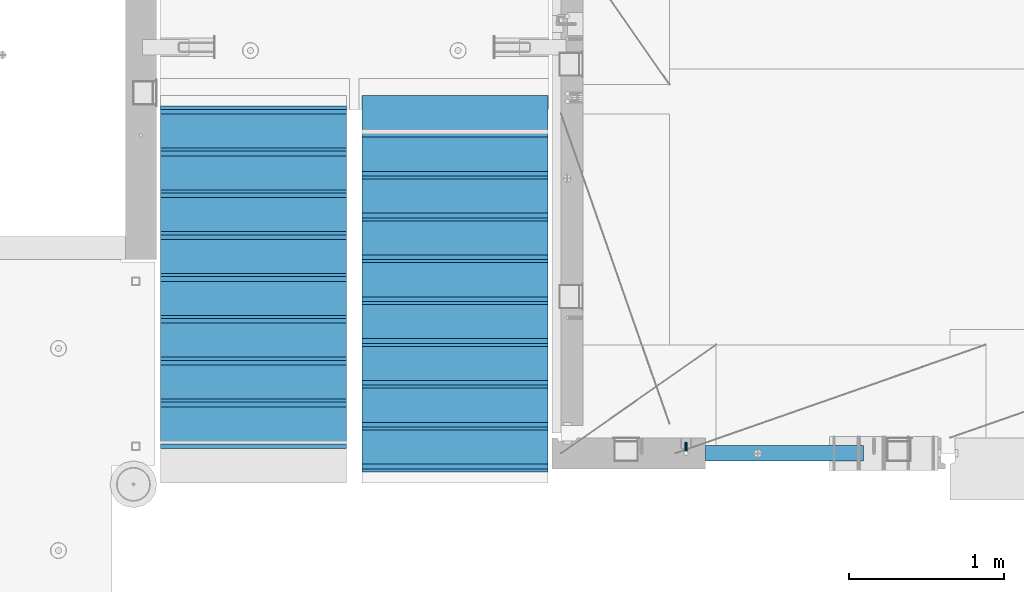
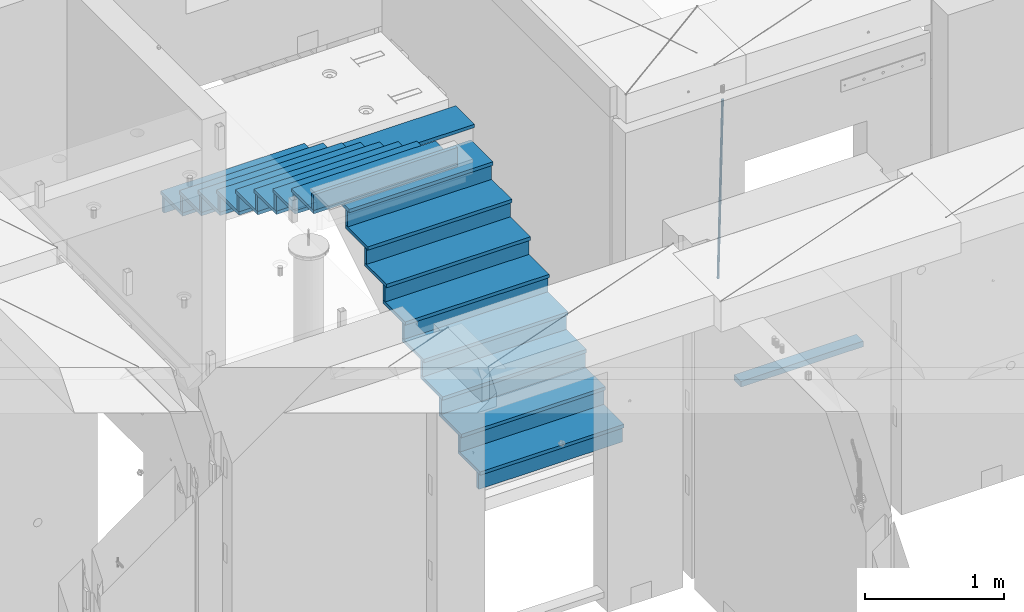
# One storey, part 114 of 341: 36 beams, 3 elements without a shape of their own.
"""IFC2X3 building model written with IfcOpenShell, lengths in millimetres."""

from ifc_helpers import new_model, si_unit, frame, origin_with_axes, place, context, subcontext, project, spatial, faceted_brep, material, type_object, element, aggregate, save


model = new_model("IFC2X3")

# Units and contexts
model_context = context("Model", 3, precision=1e-05, world=origin_with_axes())
body_context = subcontext(model_context, "Body", "Model", "MODEL_VIEW")
ifc_project = project(units=[si_unit("LENGTHUNIT", "METRE", prefix="MILLI"), si_unit("AREAUNIT", "SQUARE_METRE"), si_unit("VOLUMEUNIT", "CUBIC_METRE"), si_unit("MASSUNIT", "GRAM", prefix="KILO"), si_unit("TIMEUNIT", "SECOND"), si_unit("PLANEANGLEUNIT", "RADIAN"), si_unit("SOLIDANGLEUNIT", "STERADIAN"), si_unit("THERMODYNAMICTEMPERATUREUNIT", "DEGREE_CELSIUS"), si_unit("LUMINOUSINTENSITYUNIT", "LUMEN")], contexts=[model_context])

# Site, building, storey
site_placement = place(None, origin_with_axes())
site = spatial("IfcSite", under=ifc_project, at=site_placement, CompositionType="ELEMENT")
building_placement = place(site_placement, origin_with_axes())
building = spatial("IfcBuilding", under=site, at=building_placement, CompositionType="ELEMENT")
storey_placement = place(building_placement, origin_with_axes())
storey = spatial("IfcBuildingStorey", under=building, at=storey_placement, Name="5", CompositionType="ELEMENT", Elevation=0.0)

# Assembly, beams
assembly_1_placement = place(storey_placement, origin_with_axes())
assembly_1 = element("IfcElementAssembly", 1, at=assembly_1_placement, inside=storey, AssemblyPlace="NOTDEFINED", PredefinedType="REINFORCEMENT_UNIT")
ifc_material_1 = material()
beam_type_1 = type_object("IfcBeamType", Name="D20", PredefinedType="NOTDEFINED")
beam_1_placement = place(assembly_1_placement, frame((23075.0006866416, 17045.0000022791, 94790.0), z_axis=(0.00020576299992186, -0.999642804629538, -0.0267249099901004), x_axis=(-4.30000201928125e-08, -0.0267249099948059, 0.999642825806181)))
beam_1 = element("IfcBeam", 2, at=beam_1_placement, type_object=beam_type_1, material=ifc_material_1, Name="JM20", ObjectType="D20", context=body_context, shape_type="Brep", body=[
    faceted_brep([(0.0, -10.0, 0.0), (-4.19531716033816e-08, -7.07106781186667, -7.07106781187031), (60.4266690400545, -7.0710677960451, -7.07106780570757), (60.4266690441291, -9.99999998418934, 6.15546014159918e-09), (0.0, 0.0, -10.0), (60.426669036824, 1.58106558956206e-08, -9.99999999384454), (4.196772351861e-08, 7.07106781186303, -7.07106781186667), (60.4266690363438, 7.07106782768096, -7.07106780570757), (0.0, 10.0, 0.0), (60.4266690388904, 10.0000000158179, 6.15182216279209e-09), (4.196772351861e-08, 7.07106781185939, 7.07106781185939), (60.4266690429649, 7.07106782768096, 7.07106781802577), (0.0, 0.0, 10.0), (60.4266690461809, 1.58179318532348e-08, 10.0000000061555), (-4.19531716033816e-08, -7.07106781187031, 7.07106781185939), (60.4266690466611, -7.07106779605238, 7.07106781802213), (61.0378400410118, -7.07106779588503, -7.07106780564936), (60.991799419251, -9.99999998403655, 6.21366780251265e-09), (61.0569027789461, 1.5985278878361e-08, -9.99999999378269), (61.0378209396877, 7.07106782784831, -7.07106780564936), (60.9917724058905, 10.0000000159635, 6.21366780251265e-09), (60.9457317841297, 7.07106782781193, 7.0710678180767), (60.9266690461809, 1.59488990902901e-08, 10.0000000062028), (60.9457508854539, -7.07106779591413, 7.0710678180767), (61.6489592143771, -7.07106614513759, -7.06310863441468), (61.5568818710308, -9.9999984576425, 0.00735959856683621), (61.6870830769039, 1.71821739058942e-06, -9.99179257185824), (61.6489210170112, 7.07106947854481, -7.06310888312146), (61.556827851804, 10.0000015422847, 0.00735924683976918), (61.4647505084577, 7.07106922979438, 7.07782747982128), (61.4266266459163, 1.36643211590126e-06, 10.0065114172685), (61.464788705809, -7.07106639389531, 7.07782772852806), (176.543135720174, -7.07075579406956, -5.56673531796696), (176.451058376813, -9.99968810657447, 1.50373291501455), (176.581259582701, 0.000312069292704109, -8.49541925541052), (176.543097522794, 7.07137982961285, -5.56673556667374), (176.451004357587, 10.00031189336, 1.50373256329476), (176.35892701424, 7.07137958085514, 8.57420079627263), (176.320803151699, 0.000311717507429421, 11.5028847337162), (176.358965211621, -7.07075604281999, 8.57420104497578), (177.098753836006, -7.07075429323595, -5.55949898843028), (176.98362511232, -9.99968666800123, 1.510669025065), (177.146421932586, 0.000313595905026887, -8.48805862247536), (177.098706077581, 7.07138133041735, -5.55949936166144), (176.983557571715, 10.0003133318824, 1.51066849724157), (176.868428848029, 7.07138095712435, 8.58083651073321), (176.820760751449, 0.000313067976094317, 11.5093961447819), (176.868476606425, -7.07075466652896, 8.58083688396073), (177.654312950661, -7.07075204110879, -5.54863964998367), (177.516135294456, -9.99968450931192, 1.52107783331303), (177.711524267797, 0.000315886711177882, -8.47701274570863), (177.654255632195, 7.07138358250813, -5.54864021007961), (177.516054233929, 10.0003154905207, 1.5210770412159), (177.377876577739, 7.0713830223176, 8.59079452451624), (177.320665260588, 0.000315094497636892, 11.5191676202448), (177.377933896176, -7.07075260129932, 8.59079508461218), (299.580241614967, -7.07025777803938, -3.16539205229128), (299.442063958748, -9.99919024624614, 3.90432543100542), (299.637452932104, 0.000810149780591019, -6.09376514801625), (299.58018429653, 7.07187784557391, -3.16539261238358), (299.441982898265, 10.0008097535901, 3.90432463891557), (299.303805242045, 7.07187728538338, 10.974042122205), (299.246593924894, 0.00080935756341205, 13.9024152179336), (299.303862560482, -7.07025833822991, 10.9740426822973), (300.088882651282, -7.07025571611666, -3.15544980669438), (299.971788958996, -9.99918809853989, 3.91467979818117), (300.137357441272, 0.000812176291219657, -6.0839936725497), (300.088834180511, 7.07187990754028, -3.15545019384081), (299.971753863239, 10.0008119014747, 3.91467990454839), (299.854660170953, 7.07187951844026, 10.9848095094276), (299.806185380992, 0.000811626032373169, 13.9133533752902), (299.854708641738, -7.07025610520941, 10.9848098965813), (300.597573977022, -7.07025429077839, -3.14854421417112), (300.501599787152, -9.99918661431002, 3.92187219230618), (300.637311376035, 0.00081357714952901, -6.07720669196715), (300.597534354776, 7.07188133290401, -3.14854448120241), (300.501543752835, 10.0008133856099, 3.92187181466215), (300.40556956298, 7.07188106207104, 10.9922882211395), (300.365832163967, 0.000813194146758178, 13.9209506989318), (300.405609185211, -7.07025456160045, 10.9922884881707), (1494.60304651056, -7.06690872122999, 13.060333041718), (1494.50707232069, -9.99584104476162, 20.1307494481916), (1494.64278390956, 0.00415914670156781, 10.1316705639183), (1494.6030068883, 7.07522690244878, 13.0603327746867), (1494.50701628637, 10.004158955162, 20.1307490705476), (1494.4110420965, 7.07522663162308, 27.2011654770249), (1494.3713046975, 0.00415876370243495, 30.1298279548209), (1494.41108171875, -7.06690899205205, 27.2011657440526), (1495.1211563645, -7.06690726950183, 13.067366492749), (1495.00702625545, -9.99583964390331, 20.1375364287742), (1495.20660775043, 0.00416072652296862, 10.1393245920117), (1495.21332415029, 7.07522861253892, 13.0686179608165), (1495.13737118813, 10.0041607213934, 20.1393062718889), (1495.02324107911, 7.07522834699193, 27.2094762079141), (1494.93778969315, 0.00416035097441636, 30.1375181086514), (1494.93107329329, -7.06690753504881, 27.2082247398503), (1495.63922435709, -7.07365070849846, 13.0742491942874), (1495.5069397148, -10.00235861486, 20.1441724282631), (1495.77038591086, -0.00317370150150964, 10.1468279224828), (1495.82359171678, 7.06728286786529, 13.0767522910828), (1495.76767453534, 9.99594143344802, 20.1477123416917), (1495.63538989302, 7.0672335270865, 27.2176355756565), (1495.50422833927, -0.00324347991045215, 30.1450568474684), (1495.45102253335, -7.07370004928453, 27.2151324788683), (1517.48046966468, -7.35846502584536, 13.3649345949125), (1517.34818502239, -10.2871729322142, 20.4348578288809), (1517.61163121845, -0.287988018848409, 10.4375133231042), (1517.66483702436, 6.78246855052203, 13.3674376917079), (1517.60891984291, 9.71112711610476, 20.4383977423167), (1517.47663520063, 6.78241920973232, 27.5083209762815), (1517.34547364687, -0.288057797257352, 30.4357422480862), (1517.29226784095, -7.35851436663143, 27.5058178794898), (1518.11590717161, -7.36675126123009, 13.3733916404526), (1518.00827439407, -10.295780632965, 20.4436429663911), (1518.18994308249, -0.295529324139352, 10.4452100827657), (1518.18701289421, 6.77565927010801, 13.3743873367348), (1518.10883307132, 9.70460814510079, 20.4450510935785), (1518.00120029377, 6.77557877335857, 27.515302419517), (1517.9271643829, -0.295643163732166, 30.4434839772002), (1517.93009457119, -7.36683175797953, 27.5143067232275), (1518.75139849893, -7.36487536471395, 13.3816537936873), (1518.66841952164, -10.2938120781764, 20.4522328350286), (1518.76830418318, -0.293831718903675, 10.452712053142), (1518.7092334538, 6.77719739167878, 13.3811419616068), (1518.60878914295, 9.7060990139762, 20.4515089951637), (1518.52581016565, 6.77716230052101, 27.522088036505), (1518.50890448141, -0.293881345296541, 30.4510297770539), (1518.56797521077, -7.36491045587172, 27.5225998685855), (1618.77218426704, -7.06661321754655, 14.6790318180938), (1618.68920528975, -9.99554993101265, 21.7496108594387), (1618.78908995127, 0.0044304282637313, 11.7500900775485), (1618.73001922191, 7.07545953884255, 14.6785199860096), (1618.62957491104, 10.0043611611436, 21.748887019563), (1618.54659593375, 7.07542444768478, 28.8194660609042), (1618.52969024952, 0.00438080187086598, 31.7484078014531), (1618.58876097888, -7.06664830870795, 28.819977892992)], [[[0, 1, 2, 3]], [[1, 4, 5, 2]], [[4, 6, 7, 5]], [[6, 8, 9, 7]], [[8, 10, 11, 9]], [[10, 12, 13, 11]], [[12, 14, 15, 13]], [[14, 0, 3, 15]], [[14, 12, 10, 8, 6, 4, 1, 0]], [[3, 2, 16, 17]], [[2, 5, 18, 16]], [[5, 7, 19, 18]], [[7, 9, 20, 19]], [[9, 11, 21, 20]], [[11, 13, 22, 21]], [[13, 15, 23, 22]], [[15, 3, 17, 23]], [[17, 16, 24, 25]], [[16, 18, 26, 24]], [[18, 19, 27, 26]], [[19, 20, 28, 27]], [[20, 21, 29, 28]], [[21, 22, 30, 29]], [[22, 23, 31, 30]], [[23, 17, 25, 31]], [[25, 24, 32, 33]], [[24, 26, 34, 32]], [[26, 27, 35, 34]], [[27, 28, 36, 35]], [[28, 29, 37, 36]], [[29, 30, 38, 37]], [[30, 31, 39, 38]], [[31, 25, 33, 39]], [[33, 32, 40, 41]], [[32, 34, 42, 40]], [[34, 35, 43, 42]], [[35, 36, 44, 43]], [[36, 37, 45, 44]], [[37, 38, 46, 45]], [[38, 39, 47, 46]], [[39, 33, 41, 47]], [[41, 40, 48, 49]], [[40, 42, 50, 48]], [[42, 43, 51, 50]], [[43, 44, 52, 51]], [[44, 45, 53, 52]], [[45, 46, 54, 53]], [[46, 47, 55, 54]], [[47, 41, 49, 55]], [[49, 48, 56, 57]], [[48, 50, 58, 56]], [[50, 51, 59, 58]], [[51, 52, 60, 59]], [[52, 53, 61, 60]], [[53, 54, 62, 61]], [[54, 55, 63, 62]], [[55, 49, 57, 63]], [[57, 56, 64, 65]], [[56, 58, 66, 64]], [[58, 59, 67, 66]], [[59, 60, 68, 67]], [[60, 61, 69, 68]], [[61, 62, 70, 69]], [[62, 63, 71, 70]], [[63, 57, 65, 71]], [[65, 64, 72, 73]], [[64, 66, 74, 72]], [[66, 67, 75, 74]], [[67, 68, 76, 75]], [[68, 69, 77, 76]], [[69, 70, 78, 77]], [[70, 71, 79, 78]], [[71, 65, 73, 79]], [[73, 72, 80, 81]], [[72, 74, 82, 80]], [[74, 75, 83, 82]], [[75, 76, 84, 83]], [[76, 77, 85, 84]], [[77, 78, 86, 85]], [[78, 79, 87, 86]], [[79, 73, 81, 87]], [[81, 80, 88, 89]], [[80, 82, 90, 88]], [[82, 83, 91, 90]], [[83, 84, 92, 91]], [[84, 85, 93, 92]], [[85, 86, 94, 93]], [[86, 87, 95, 94]], [[87, 81, 89, 95]], [[89, 88, 96, 97]], [[88, 90, 98, 96]], [[90, 91, 99, 98]], [[91, 92, 100, 99]], [[92, 93, 101, 100]], [[93, 94, 102, 101]], [[94, 95, 103, 102]], [[95, 89, 97, 103]], [[97, 96, 104, 105]], [[96, 98, 106, 104]], [[98, 99, 107, 106]], [[99, 100, 108, 107]], [[100, 101, 109, 108]], [[101, 102, 110, 109]], [[102, 103, 111, 110]], [[103, 97, 105, 111]], [[105, 104, 112, 113]], [[104, 106, 114, 112]], [[106, 107, 115, 114]], [[107, 108, 116, 115]], [[108, 109, 117, 116]], [[109, 110, 118, 117]], [[110, 111, 119, 118]], [[111, 105, 113, 119]], [[113, 112, 120, 121]], [[112, 114, 122, 120]], [[114, 115, 123, 122]], [[115, 116, 124, 123]], [[116, 117, 125, 124]], [[117, 118, 126, 125]], [[118, 119, 127, 126]], [[119, 113, 121, 127]], [[121, 120, 128, 129]], [[120, 122, 130, 128]], [[122, 123, 131, 130]], [[123, 124, 132, 131]], [[124, 125, 133, 132]], [[125, 126, 134, 133]], [[126, 127, 135, 134]], [[127, 121, 129, 135]], [[130, 131, 132, 133, 134, 135, 129, 128]]]),
])
ifc_material_2 = material(Name="TIMBER/T24")
beam_type_2 = type_object("IfcBeamType", PredefinedType="NOTDEFINED")
beam_2_placement = place(assembly_1_placement, frame((23200.0006866455, 16980.0, 93880.0), z_axis=(0.0, 0.0, 1.0), x_axis=(1.0, 0.0, 0.0)))
beam_2 = element("IfcBeam", 3, at=beam_2_placement, type_object=beam_type_2, material=ifc_material_2, context=body_context, shape_type="Brep", body=[
    faceted_brep([(0.0, 50.0, -25.0), (0.0, 50.0, 25.0), (1020.0, 50.0, 25.0), (1020.0, 50.0, -25.0), (0.0, -50.0, 25.0), (1020.0, -50.0, 25.0), (0.0, -50.0, -25.0), (1020.0, -50.0, -25.0)], [[[0, 1, 2, 3]], [[1, 4, 5, 2]], [[4, 6, 7, 5]], [[6, 0, 3, 7]], [[5, 7, 3, 2]], [[6, 4, 1, 0]]]),
])
aggregate(assembly_1, [beam_1, beam_2])

assembly_2_placement = place(storey_placement, origin_with_axes())
assembly_2 = element("IfcElementAssembly", 4, at=assembly_2_placement, inside=storey, Name="E9", AssemblyPlace="NOTDEFINED", PredefinedType="NOTDEFINED")
ifc_material_3 = material(Name="Undefined/C32/40")
beam_type_3 = type_object("IfcBeamType", PredefinedType="NOTDEFINED")
beam_3_placement = place(assembly_2_placement, frame((20885.0002457424, 17024.9998138874, 96662.1), z_axis=(0.0, 1.0, 0.0), x_axis=(-1.0, 3.00000001838171e-08, 0.0)))
beam_3 = element("IfcBeam", 5, at=beam_3_placement, type_object=beam_type_3, material=ifc_material_3, Name="E9", context=body_context, shape_type="Brep", body=[
    faceted_brep([(0.0, 68.5, -15.0), (0.0, 68.5, 15.0), (1200.0, 68.5, 15.0), (1200.0, 68.5, -15.0), (0.0, -68.5, 15.0), (1200.0, -68.5, 15.0), (0.0, -68.5, -15.0), (1200.0, -68.5, -15.0)], [[[0, 1, 2, 3]], [[1, 4, 5, 2]], [[4, 6, 7, 5]], [[6, 0, 3, 7]], [[5, 7, 3, 2]], [[6, 4, 1, 0]]]),
])
beam_4_placement = place(assembly_2_placement, frame((20885.0002457424, 17294.9998138874, 96495.4), z_axis=(0.0, 1.0, 0.0), x_axis=(-1.0, 3.00000001838171e-08, 0.0)))
beam_4 = element("IfcBeam", 6, at=beam_4_placement, type_object=beam_type_3, material=ifc_material_3, Name="E9", context=body_context, shape_type="Brep", body=[
    faceted_brep([(0.0, 68.5, -15.0), (0.0, 68.5, 15.0), (1200.0, 68.5, 15.0), (1200.0, 68.5, -15.0), (0.0, -68.5, 15.0), (1200.0, -68.5, 15.0), (0.0, -68.5, -15.0), (1200.0, -68.5, -15.0)], [[[0, 1, 2, 3]], [[1, 4, 5, 2]], [[4, 6, 7, 5]], [[6, 0, 3, 7]], [[5, 7, 3, 2]], [[6, 4, 1, 0]]]),
])
beam_5_placement = place(assembly_2_placement, frame((20885.0002457424, 17564.9998138874, 96328.7), z_axis=(0.0, 1.0, 0.0), x_axis=(-1.0, 3.00000001838171e-08, 0.0)))
beam_5 = element("IfcBeam", 7, at=beam_5_placement, type_object=beam_type_3, material=ifc_material_3, Name="E9", context=body_context, shape_type="Brep", body=[
    faceted_brep([(0.0, 68.5, -15.0), (0.0, 68.5, 15.0), (1200.0, 68.5, 15.0), (1200.0, 68.5, -15.0), (0.0, -68.5, 15.0), (1200.0, -68.5, 15.0), (0.0, -68.5, -15.0), (1200.0, -68.5, -15.0)], [[[0, 1, 2, 3]], [[1, 4, 5, 2]], [[4, 6, 7, 5]], [[6, 0, 3, 7]], [[5, 7, 3, 2]], [[6, 4, 1, 0]]]),
])
beam_6_placement = place(assembly_2_placement, frame((20885.0002457424, 17834.9998138874, 96162.0), z_axis=(0.0, 1.0, 0.0), x_axis=(-1.0, 3.00000001838171e-08, 0.0)))
beam_6 = element("IfcBeam", 8, at=beam_6_placement, type_object=beam_type_3, material=ifc_material_3, Name="E9", context=body_context, shape_type="Brep", body=[
    faceted_brep([(0.0, 68.5, -15.0), (0.0, 68.5, 15.0), (1200.0, 68.5, 15.0), (1200.0, 68.5, -15.0), (0.0, -68.5, 15.0), (1200.0, -68.5, 15.0), (0.0, -68.5, -15.0), (1200.0, -68.5, -15.0)], [[[0, 1, 2, 3]], [[1, 4, 5, 2]], [[4, 6, 7, 5]], [[6, 0, 3, 7]], [[5, 7, 3, 2]], [[6, 4, 1, 0]]]),
])
beam_7_placement = place(assembly_2_placement, frame((20885.0002457424, 18104.9998138874, 95995.3), z_axis=(0.0, 1.0, 0.0), x_axis=(-1.0, 3.00000001838171e-08, 0.0)))
beam_7 = element("IfcBeam", 9, at=beam_7_placement, type_object=beam_type_3, material=ifc_material_3, Name="E9", context=body_context, shape_type="Brep", body=[
    faceted_brep([(0.0, 68.5, -15.0), (0.0, 68.5, 15.0), (1200.0, 68.5, 15.0), (1200.0, 68.5, -15.0), (0.0, -68.5, 15.0), (1200.0, -68.5, 15.0), (0.0, -68.5, -15.0), (1200.0, -68.5, -15.0)], [[[0, 1, 2, 3]], [[1, 4, 5, 2]], [[4, 6, 7, 5]], [[6, 0, 3, 7]], [[5, 7, 3, 2]], [[6, 4, 1, 0]]]),
])
beam_8_placement = place(assembly_2_placement, frame((20885.0002457424, 18374.9998138874, 95828.6), z_axis=(0.0, 1.0, 0.0), x_axis=(-1.0, 3.00000001838171e-08, 0.0)))
beam_8 = element("IfcBeam", 10, at=beam_8_placement, type_object=beam_type_3, material=ifc_material_3, Name="E9", context=body_context, shape_type="Brep", body=[
    faceted_brep([(0.0, 68.5, -15.0), (0.0, 68.5, 15.0), (1200.0, 68.5, 15.0), (1200.0, 68.5, -15.0), (0.0, -68.5, 15.0), (1200.0, -68.5, 15.0), (0.0, -68.5, -15.0), (1200.0, -68.5, -15.0)], [[[0, 1, 2, 3]], [[1, 4, 5, 2]], [[4, 6, 7, 5]], [[6, 0, 3, 7]], [[5, 7, 3, 2]], [[6, 4, 1, 0]]]),
])
beam_9_placement = place(assembly_2_placement, frame((20885.0002457424, 18644.9998138874, 95661.9), z_axis=(0.0, 1.0, 0.0), x_axis=(-1.0, 3.00000001838171e-08, 0.0)))
beam_9 = element("IfcBeam", 11, at=beam_9_placement, type_object=beam_type_3, material=ifc_material_3, Name="E9", context=body_context, shape_type="Brep", body=[
    faceted_brep([(0.0, 68.5, -15.0), (0.0, 68.5, 15.0), (1200.0, 68.5, 15.0), (1200.0, 68.5, -15.0), (0.0, -68.5, 15.0), (1200.0, -68.5, 15.0), (0.0, -68.5, -15.0), (1200.0, -68.5, -15.0)], [[[0, 1, 2, 3]], [[1, 4, 5, 2]], [[4, 6, 7, 5]], [[6, 0, 3, 7]], [[5, 7, 3, 2]], [[6, 4, 1, 0]]]),
])
beam_10_placement = place(assembly_2_placement, frame((20885.0002457424, 18914.9998138874, 95495.2), z_axis=(0.0, 1.0, 0.0), x_axis=(-1.0, 3.00000001838171e-08, 0.0)))
beam_10 = element("IfcBeam", 12, at=beam_10_placement, type_object=beam_type_3, material=ifc_material_3, Name="E9", context=body_context, shape_type="Brep", body=[
    faceted_brep([(0.0, 68.5, -15.0), (0.0, 68.5, 15.0), (1200.0, 68.5, 15.0), (1200.0, 68.5, -15.0), (0.0, -68.5, 15.0), (1200.0, -68.5, 15.0), (0.0, -68.5, -15.0), (1200.0, -68.5, -15.0)], [[[0, 1, 2, 3]], [[1, 4, 5, 2]], [[4, 6, 7, 5]], [[6, 0, 3, 7]], [[5, 7, 3, 2]], [[6, 4, 1, 0]]]),
])
beam_11_placement = place(assembly_2_placement, frame((20885.0002457424, 19184.9998138874, 95328.5), z_axis=(0.0, 1.0, 0.0), x_axis=(-1.0, 3.00000001838171e-08, 0.0)))
beam_11 = element("IfcBeam", 13, at=beam_11_placement, type_object=beam_type_3, material=ifc_material_3, Name="E9", context=body_context, shape_type="Brep", body=[
    faceted_brep([(0.0, 68.5, -15.0), (0.0, 68.5, 15.0), (1200.0, 68.5, 15.0), (1200.0, 68.5, -15.0), (0.0, -68.5, 15.0), (1200.0, -68.5, 15.0), (0.0, -68.5, -15.0), (1200.0, -68.5, -15.0)], [[[0, 1, 2, 3]], [[1, 4, 5, 2]], [[4, 6, 7, 5]], [[6, 0, 3, 7]], [[5, 7, 3, 2]], [[6, 4, 1, 0]]]),
])

assembly_3_placement = place(storey_placement, origin_with_axes())
assembly_3 = element("IfcElementAssembly", 14, at=assembly_3_placement, inside=storey, Name="E9", AssemblyPlace="NOTDEFINED", PredefinedType="NOTDEFINED")
beam_12_placement = place(assembly_3_placement, frame((20985.002175553, 18785.001025346, 94995.1036072969), z_axis=(0.0, -1.0, 0.0), x_axis=(1.0, 0.0, 0.0)))
beam_12 = element("IfcBeam", 15, at=beam_12_placement, type_object=beam_type_3, material=ifc_material_3, Name="E9", context=body_context, shape_type="Brep", body=[
    faceted_brep([(0.0, 68.5, -15.0), (0.0, 68.5, 15.0), (1200.0, 68.5, 15.0), (1200.0, 68.5, -15.0), (0.0, -68.5, 15.0), (1200.0, -68.5, 15.0), (0.0, -68.5, -15.0), (1200.0, -68.5, -15.0)], [[[0, 1, 2, 3]], [[1, 4, 5, 2]], [[4, 6, 7, 5]], [[6, 0, 3, 7]], [[5, 7, 3, 2]], [[6, 4, 1, 0]]]),
])
beam_13_placement = place(assembly_3_placement, frame((20985.002175553, 18515.001025346, 94828.4036072969), z_axis=(0.0, -1.0, 0.0), x_axis=(1.0, 0.0, 0.0)))
beam_13 = element("IfcBeam", 16, at=beam_13_placement, type_object=beam_type_3, material=ifc_material_3, Name="E9", context=body_context, shape_type="Brep", body=[
    faceted_brep([(0.0, 68.5, -15.0), (0.0, 68.5, 15.0), (1200.0, 68.5, 15.0), (1200.0, 68.5, -15.0), (0.0, -68.5, 15.0), (1200.0, -68.5, 15.0), (0.0, -68.5, -15.0), (1200.0, -68.5, -15.0)], [[[0, 1, 2, 3]], [[1, 4, 5, 2]], [[4, 6, 7, 5]], [[6, 0, 3, 7]], [[5, 7, 3, 2]], [[6, 4, 1, 0]]]),
])
beam_14_placement = place(assembly_3_placement, frame((20985.002175553, 18245.001025346, 94661.7036072969), z_axis=(0.0, -1.0, 0.0), x_axis=(1.0, 0.0, 0.0)))
beam_14 = element("IfcBeam", 17, at=beam_14_placement, type_object=beam_type_3, material=ifc_material_3, Name="E9", context=body_context, shape_type="Brep", body=[
    faceted_brep([(0.0, 68.5, -15.0), (0.0, 68.5, 15.0), (1200.0, 68.5, 15.0), (1200.0, 68.5, -15.0), (0.0, -68.5, 15.0), (1200.0, -68.5, 15.0), (0.0, -68.5, -15.0), (1200.0, -68.5, -15.0)], [[[0, 1, 2, 3]], [[1, 4, 5, 2]], [[4, 6, 7, 5]], [[6, 0, 3, 7]], [[5, 7, 3, 2]], [[6, 4, 1, 0]]]),
])
beam_15_placement = place(assembly_3_placement, frame((20985.002175553, 17975.001025346, 94495.0036072969), z_axis=(0.0, -1.0, 0.0), x_axis=(1.0, 0.0, 0.0)))
beam_15 = element("IfcBeam", 18, at=beam_15_placement, type_object=beam_type_3, material=ifc_material_3, Name="E9", context=body_context, shape_type="Brep", body=[
    faceted_brep([(0.0, 68.5, -15.0), (0.0, 68.5, 15.0), (1200.0, 68.5, 15.0), (1200.0, 68.5, -15.0), (0.0, -68.5, 15.0), (1200.0, -68.5, 15.0), (0.0, -68.5, -15.0), (1200.0, -68.5, -15.0)], [[[0, 1, 2, 3]], [[1, 4, 5, 2]], [[4, 6, 7, 5]], [[6, 0, 3, 7]], [[5, 7, 3, 2]], [[6, 4, 1, 0]]]),
])
beam_16_placement = place(assembly_3_placement, frame((20985.002175553, 17705.001025346, 94328.3036072969), z_axis=(0.0, -1.0, 0.0), x_axis=(1.0, 0.0, 0.0)))
beam_16 = element("IfcBeam", 19, at=beam_16_placement, type_object=beam_type_3, material=ifc_material_3, Name="E9", context=body_context, shape_type="Brep", body=[
    faceted_brep([(0.0, 68.5, -15.0), (0.0, 68.5, 15.0), (1200.0, 68.5, 15.0), (1200.0, 68.5, -15.0), (0.0, -68.5, 15.0), (1200.0, -68.5, 15.0), (0.0, -68.5, -15.0), (1200.0, -68.5, -15.0)], [[[0, 1, 2, 3]], [[1, 4, 5, 2]], [[4, 6, 7, 5]], [[6, 0, 3, 7]], [[5, 7, 3, 2]], [[6, 4, 1, 0]]]),
])
beam_17_placement = place(assembly_3_placement, frame((20985.002175553, 17435.001025346, 94161.6036072969), z_axis=(0.0, -1.0, 0.0), x_axis=(1.0, 0.0, 0.0)))
beam_17 = element("IfcBeam", 20, at=beam_17_placement, type_object=beam_type_3, material=ifc_material_3, Name="E9", context=body_context, shape_type="Brep", body=[
    faceted_brep([(0.0, 68.5, -15.0), (0.0, 68.5, 15.0), (1200.0, 68.5, 15.0), (1200.0, 68.5, -15.0), (0.0, -68.5, 15.0), (1200.0, -68.5, 15.0), (0.0, -68.5, -15.0), (1200.0, -68.5, -15.0)], [[[0, 1, 2, 3]], [[1, 4, 5, 2]], [[4, 6, 7, 5]], [[6, 0, 3, 7]], [[5, 7, 3, 2]], [[6, 4, 1, 0]]]),
])
beam_18_placement = place(assembly_3_placement, frame((20985.002175553, 17165.001025346, 93994.9036072969), z_axis=(0.0, -1.0, 0.0), x_axis=(1.0, 0.0, 0.0)))
beam_18 = element("IfcBeam", 21, at=beam_18_placement, type_object=beam_type_3, material=ifc_material_3, Name="E9", context=body_context, shape_type="Brep", body=[
    faceted_brep([(0.0, 68.5, -15.0), (0.0, 68.5, 15.0), (1200.0, 68.5, 15.0), (1200.0, 68.5, -15.0), (0.0, -68.5, 15.0), (1200.0, -68.5, 15.0), (0.0, -68.5, -15.0), (1200.0, -68.5, -15.0)], [[[0, 1, 2, 3]], [[1, 4, 5, 2]], [[4, 6, 7, 5]], [[6, 0, 3, 7]], [[5, 7, 3, 2]], [[6, 4, 1, 0]]]),
])
beam_19_placement = place(assembly_3_placement, frame((20985.002175553, 16895.001025346, 93828.2036072969), z_axis=(0.0, -1.0, 0.0), x_axis=(1.0, 0.0, 0.0)))
beam_19 = element("IfcBeam", 22, at=beam_19_placement, type_object=beam_type_3, material=ifc_material_3, Name="E9", context=body_context, shape_type="Brep", body=[
    faceted_brep([(0.0, 68.5, -15.0), (0.0, 68.5, 15.0), (1200.0, 68.5, 15.0), (1200.0, 68.5, -15.0), (0.0, -68.5, 15.0), (1200.0, -68.5, 15.0), (0.0, -68.5, -15.0), (1200.0, -68.5, -15.0)], [[[0, 1, 2, 3]], [[1, 4, 5, 2]], [[4, 6, 7, 5]], [[6, 0, 3, 7]], [[5, 7, 3, 2]], [[6, 4, 1, 0]]]),
])

# Beam
beam_type_4 = type_object("IfcBeamType", PredefinedType="NOTDEFINED")
beam_20_placement = place(assembly_2_placement, frame((20885.0002457424, 17169.9998138874, 96578.6), z_axis=(0.0, 1.0, 0.0), x_axis=(-1.0, 3.00000001838171e-08, 0.0)))
beam_20 = element("IfcBeam", 23, at=beam_20_placement, type_object=beam_type_4, material=ifc_material_3, Name="E9", context=body_context, shape_type="Brep", body=[
    faceted_brep([(0.0, 15.0, -160.0), (0.0, 15.0, 160.0), (1200.0, 15.0, 160.0), (1200.0, 15.0, -160.0), (0.0, -15.0, 160.0), (1200.0, -15.0, 160.0), (0.0, -15.0, -160.0), (1200.0, -15.0, -160.0)], [[[0, 1, 2, 3]], [[1, 4, 5, 2]], [[4, 6, 7, 5]], [[6, 0, 3, 7]], [[5, 7, 3, 2]], [[6, 4, 1, 0]]]),
])

beam_21_placement = place(assembly_2_placement, frame((20885.0002457424, 17439.9998138874, 96411.9), z_axis=(0.0, 1.0, 0.0), x_axis=(-1.0, 3.00000001838171e-08, 0.0)))
beam_21 = element("IfcBeam", 24, at=beam_21_placement, type_object=beam_type_4, material=ifc_material_3, Name="E9", context=body_context, shape_type="Brep", body=[
    faceted_brep([(0.0, 15.0, -160.0), (0.0, 15.0, 160.0), (1200.0, 15.0, 160.0), (1200.0, 15.0, -160.0), (0.0, -15.0, 160.0), (1200.0, -15.0, 160.0), (0.0, -15.0, -160.0), (1200.0, -15.0, -160.0)], [[[0, 1, 2, 3]], [[1, 4, 5, 2]], [[4, 6, 7, 5]], [[6, 0, 3, 7]], [[5, 7, 3, 2]], [[6, 4, 1, 0]]]),
])

beam_22_placement = place(assembly_2_placement, frame((20885.0002457424, 17709.9998138874, 96245.2), z_axis=(0.0, 1.0, 0.0), x_axis=(-1.0, 3.00000001838171e-08, 0.0)))
beam_22 = element("IfcBeam", 25, at=beam_22_placement, type_object=beam_type_4, material=ifc_material_3, Name="E9", context=body_context, shape_type="Brep", body=[
    faceted_brep([(0.0, 15.0, -160.0), (0.0, 15.0, 160.0), (1200.0, 15.0, 160.0), (1200.0, 15.0, -160.0), (0.0, -15.0, 160.0), (1200.0, -15.0, 160.0), (0.0, -15.0, -160.0), (1200.0, -15.0, -160.0)], [[[0, 1, 2, 3]], [[1, 4, 5, 2]], [[4, 6, 7, 5]], [[6, 0, 3, 7]], [[5, 7, 3, 2]], [[6, 4, 1, 0]]]),
])

beam_23_placement = place(assembly_2_placement, frame((20885.0002457424, 17979.9998138874, 96078.5), z_axis=(0.0, 1.0, 0.0), x_axis=(-1.0, 3.00000001838171e-08, 0.0)))
beam_23 = element("IfcBeam", 26, at=beam_23_placement, type_object=beam_type_4, material=ifc_material_3, Name="E9", context=body_context, shape_type="Brep", body=[
    faceted_brep([(0.0, 15.0, -160.0), (0.0, 15.0, 160.0), (1200.0, 15.0, 160.0), (1200.0, 15.0, -160.0), (0.0, -15.0, 160.0), (1200.0, -15.0, 160.0), (0.0, -15.0, -160.0), (1200.0, -15.0, -160.0)], [[[0, 1, 2, 3]], [[1, 4, 5, 2]], [[4, 6, 7, 5]], [[6, 0, 3, 7]], [[5, 7, 3, 2]], [[6, 4, 1, 0]]]),
])

beam_24_placement = place(assembly_2_placement, frame((20885.0002457424, 18249.9998138874, 95911.8), z_axis=(0.0, 1.0, 0.0), x_axis=(-1.0, 3.00000001838171e-08, 0.0)))
beam_24 = element("IfcBeam", 27, at=beam_24_placement, type_object=beam_type_4, material=ifc_material_3, Name="E9", context=body_context, shape_type="Brep", body=[
    faceted_brep([(0.0, 15.0, -160.0), (0.0, 15.0, 160.0), (1200.0, 15.0, 160.0), (1200.0, 15.0, -160.0), (0.0, -15.0, 160.0), (1200.0, -15.0, 160.0), (0.0, -15.0, -160.0), (1200.0, -15.0, -160.0)], [[[0, 1, 2, 3]], [[1, 4, 5, 2]], [[4, 6, 7, 5]], [[6, 0, 3, 7]], [[5, 7, 3, 2]], [[6, 4, 1, 0]]]),
])

beam_25_placement = place(assembly_2_placement, frame((20885.0002457424, 18519.9998138874, 95745.1), z_axis=(0.0, 1.0, 0.0), x_axis=(-1.0, 3.00000001838171e-08, 0.0)))
beam_25 = element("IfcBeam", 28, at=beam_25_placement, type_object=beam_type_4, material=ifc_material_3, Name="E9", context=body_context, shape_type="Brep", body=[
    faceted_brep([(0.0, 15.0, -160.0), (0.0, 15.0, 160.0), (1200.0, 15.0, 160.0), (1200.0, 15.0, -160.0), (0.0, -15.0, 160.0), (1200.0, -15.0, 160.0), (0.0, -15.0, -160.0), (1200.0, -15.0, -160.0)], [[[0, 1, 2, 3]], [[1, 4, 5, 2]], [[4, 6, 7, 5]], [[6, 0, 3, 7]], [[5, 7, 3, 2]], [[6, 4, 1, 0]]]),
])

beam_26_placement = place(assembly_2_placement, frame((20885.0002457424, 18789.9998138874, 95578.4), z_axis=(0.0, 1.0, 0.0), x_axis=(-1.0, 3.00000001838171e-08, 0.0)))
beam_26 = element("IfcBeam", 29, at=beam_26_placement, type_object=beam_type_4, material=ifc_material_3, Name="E9", context=body_context, shape_type="Brep", body=[
    faceted_brep([(0.0, 15.0, -160.0), (0.0, 15.0, 160.0), (1200.0, 15.0, 160.0), (1200.0, 15.0, -160.0), (0.0, -15.0, 160.0), (1200.0, -15.0, 160.0), (0.0, -15.0, -160.0), (1200.0, -15.0, -160.0)], [[[0, 1, 2, 3]], [[1, 4, 5, 2]], [[4, 6, 7, 5]], [[6, 0, 3, 7]], [[5, 7, 3, 2]], [[6, 4, 1, 0]]]),
])

beam_27_placement = place(assembly_2_placement, frame((20885.0002457424, 19059.9998138874, 95411.7), z_axis=(0.0, 1.0, 0.0), x_axis=(-1.0, 3.00000001838171e-08, 0.0)))
beam_27 = element("IfcBeam", 30, at=beam_27_placement, type_object=beam_type_4, material=ifc_material_3, Name="E9", context=body_context, shape_type="Brep", body=[
    faceted_brep([(0.0, 15.0, -160.0), (0.0, 15.0, 160.0), (1200.0, 15.0, 160.0), (1200.0, 15.0, -160.0), (0.0, -15.0, 160.0), (1200.0, -15.0, 160.0), (0.0, -15.0, -160.0), (1200.0, -15.0, -160.0)], [[[0, 1, 2, 3]], [[1, 4, 5, 2]], [[4, 6, 7, 5]], [[6, 0, 3, 7]], [[5, 7, 3, 2]], [[6, 4, 1, 0]]]),
])

aggregate(assembly_2, [beam_3, beam_20, beam_4, beam_21, beam_5, beam_22, beam_6, beam_23, beam_7, beam_24, beam_8, beam_25, beam_9, beam_26, beam_10, beam_27, beam_11])

beam_28_placement = place(assembly_3_placement, frame((20985.002175553, 18910.001025346, 95078.303607297), z_axis=(0.0, -1.0, 0.0), x_axis=(1.0, 0.0, 0.0)))
beam_28 = element("IfcBeam", 31, at=beam_28_placement, type_object=beam_type_4, material=ifc_material_3, Name="E9", context=body_context, shape_type="Brep", body=[
    faceted_brep([(0.0, 15.0, -160.0), (0.0, 15.0, 160.0), (1200.0, 15.0, 160.0), (1200.0, 15.0, -160.0), (0.0, -15.0, 160.0), (1200.0, -15.0, 160.0), (0.0, -15.0, -160.0), (1200.0, -15.0, -160.0)], [[[0, 1, 2, 3]], [[1, 4, 5, 2]], [[4, 6, 7, 5]], [[6, 0, 3, 7]], [[5, 7, 3, 2]], [[6, 4, 1, 0]]]),
])

beam_29_placement = place(assembly_3_placement, frame((20985.002175553, 18640.001025346, 94911.6036072969), z_axis=(0.0, -1.0, 0.0), x_axis=(1.0, 0.0, 0.0)))
beam_29 = element("IfcBeam", 32, at=beam_29_placement, type_object=beam_type_4, material=ifc_material_3, Name="E9", context=body_context, shape_type="Brep", body=[
    faceted_brep([(0.0, 15.0, -160.0), (0.0, 15.0, 160.0), (1200.0, 15.0, 160.0), (1200.0, 15.0, -160.0), (0.0, -15.0, 160.0), (1200.0, -15.0, 160.0), (0.0, -15.0, -160.0), (1200.0, -15.0, -160.0)], [[[0, 1, 2, 3]], [[1, 4, 5, 2]], [[4, 6, 7, 5]], [[6, 0, 3, 7]], [[5, 7, 3, 2]], [[6, 4, 1, 0]]]),
])

beam_30_placement = place(assembly_3_placement, frame((20985.002175553, 18370.001025346, 94744.9036072969), z_axis=(0.0, -1.0, 0.0), x_axis=(1.0, 0.0, 0.0)))
beam_30 = element("IfcBeam", 33, at=beam_30_placement, type_object=beam_type_4, material=ifc_material_3, Name="E9", context=body_context, shape_type="Brep", body=[
    faceted_brep([(0.0, 15.0, -160.0), (0.0, 15.0, 160.0), (1200.0, 15.0, 160.0), (1200.0, 15.0, -160.0), (0.0, -15.0, 160.0), (1200.0, -15.0, 160.0), (0.0, -15.0, -160.0), (1200.0, -15.0, -160.0)], [[[0, 1, 2, 3]], [[1, 4, 5, 2]], [[4, 6, 7, 5]], [[6, 0, 3, 7]], [[5, 7, 3, 2]], [[6, 4, 1, 0]]]),
])

beam_31_placement = place(assembly_3_placement, frame((20985.002175553, 18100.001025346, 94578.2036072969), z_axis=(0.0, -1.0, 0.0), x_axis=(1.0, 0.0, 0.0)))
beam_31 = element("IfcBeam", 34, at=beam_31_placement, type_object=beam_type_4, material=ifc_material_3, Name="E9", context=body_context, shape_type="Brep", body=[
    faceted_brep([(0.0, 15.0, -160.0), (0.0, 15.0, 160.0), (1200.0, 15.0, 160.0), (1200.0, 15.0, -160.0), (0.0, -15.0, 160.0), (1200.0, -15.0, 160.0), (0.0, -15.0, -160.0), (1200.0, -15.0, -160.0)], [[[0, 1, 2, 3]], [[1, 4, 5, 2]], [[4, 6, 7, 5]], [[6, 0, 3, 7]], [[5, 7, 3, 2]], [[6, 4, 1, 0]]]),
])

beam_32_placement = place(assembly_3_placement, frame((20985.002175553, 17830.001025346, 94411.5036072969), z_axis=(0.0, -1.0, 0.0), x_axis=(1.0, 0.0, 0.0)))
beam_32 = element("IfcBeam", 35, at=beam_32_placement, type_object=beam_type_4, material=ifc_material_3, Name="E9", context=body_context, shape_type="Brep", body=[
    faceted_brep([(0.0, 15.0, -160.0), (0.0, 15.0, 160.0), (1200.0, 15.0, 160.0), (1200.0, 15.0, -160.0), (0.0, -15.0, 160.0), (1200.0, -15.0, 160.0), (0.0, -15.0, -160.0), (1200.0, -15.0, -160.0)], [[[0, 1, 2, 3]], [[1, 4, 5, 2]], [[4, 6, 7, 5]], [[6, 0, 3, 7]], [[5, 7, 3, 2]], [[6, 4, 1, 0]]]),
])

beam_33_placement = place(assembly_3_placement, frame((20985.002175553, 17560.001025346, 94244.8036072969), z_axis=(0.0, -1.0, 0.0), x_axis=(1.0, 0.0, 0.0)))
beam_33 = element("IfcBeam", 36, at=beam_33_placement, type_object=beam_type_4, material=ifc_material_3, Name="E9", context=body_context, shape_type="Brep", body=[
    faceted_brep([(0.0, 15.0, -160.0), (0.0, 15.0, 160.0), (1200.0, 15.0, 160.0), (1200.0, 15.0, -160.0), (0.0, -15.0, 160.0), (1200.0, -15.0, 160.0), (0.0, -15.0, -160.0), (1200.0, -15.0, -160.0)], [[[0, 1, 2, 3]], [[1, 4, 5, 2]], [[4, 6, 7, 5]], [[6, 0, 3, 7]], [[5, 7, 3, 2]], [[6, 4, 1, 0]]]),
])

beam_34_placement = place(assembly_3_placement, frame((20985.002175553, 17290.001025346, 94078.1036072969), z_axis=(0.0, -1.0, 0.0), x_axis=(1.0, 0.0, 0.0)))
beam_34 = element("IfcBeam", 37, at=beam_34_placement, type_object=beam_type_4, material=ifc_material_3, Name="E9", context=body_context, shape_type="Brep", body=[
    faceted_brep([(0.0, 15.0, -160.0), (0.0, 15.0, 160.0), (1200.0, 15.0, 160.0), (1200.0, 15.0, -160.0), (0.0, -15.0, 160.0), (1200.0, -15.0, 160.0), (0.0, -15.0, -160.0), (1200.0, -15.0, -160.0)], [[[0, 1, 2, 3]], [[1, 4, 5, 2]], [[4, 6, 7, 5]], [[6, 0, 3, 7]], [[5, 7, 3, 2]], [[6, 4, 1, 0]]]),
])

beam_35_placement = place(assembly_3_placement, frame((20985.002175553, 17020.001025346, 93911.4036072969), z_axis=(0.0, -1.0, 0.0), x_axis=(1.0, 0.0, 0.0)))
beam_35 = element("IfcBeam", 38, at=beam_35_placement, type_object=beam_type_4, material=ifc_material_3, Name="E9", context=body_context, shape_type="Brep", body=[
    faceted_brep([(0.0, 15.0, -160.0), (0.0, 15.0, 160.0), (1200.0, 15.0, 160.0), (1200.0, 15.0, -160.0), (0.0, -15.0, 160.0), (1200.0, -15.0, 160.0), (0.0, -15.0, -160.0), (1200.0, -15.0, -160.0)], [[[0, 1, 2, 3]], [[1, 4, 5, 2]], [[4, 6, 7, 5]], [[6, 0, 3, 7]], [[5, 7, 3, 2]], [[6, 4, 1, 0]]]),
])

beam_type_5 = type_object("IfcBeamType", PredefinedType="NOTDEFINED")
beam_36_placement = place(assembly_3_placement, frame((20985.002175553, 19155.001025346, 95245.003607297), z_axis=(0.0, -1.0, 0.0), x_axis=(1.0, 0.0, 0.0)))
beam_36 = element("IfcBeam", 39, at=beam_36_placement, type_object=beam_type_5, material=ifc_material_3, Name="E9", context=body_context, shape_type="Brep", body=[
    faceted_brep([(0.0, 15.0, -135.0), (0.0, 15.0, 135.0), (1200.0, 15.0, 135.0), (1200.0, 15.0, -135.0), (0.0, -15.0, 135.0), (1200.0, -15.0, 135.0), (0.0, -15.0, -135.0), (1200.0, -15.0, -135.0)], [[[0, 1, 2, 3]], [[1, 4, 5, 2]], [[4, 6, 7, 5]], [[6, 0, 3, 7]], [[5, 7, 3, 2]], [[6, 4, 1, 0]]]),
])

aggregate(assembly_3, [beam_28, beam_12, beam_29, beam_13, beam_30, beam_14, beam_31, beam_15, beam_32, beam_16, beam_33, beam_17, beam_34, beam_18, beam_35, beam_36, beam_19])

save(model, "model.ifc")
